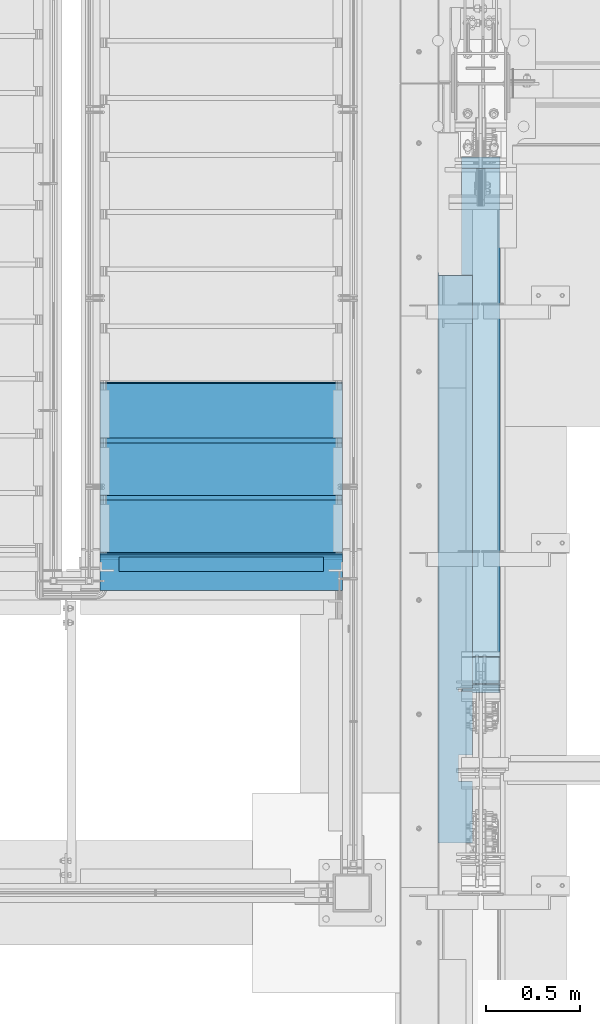
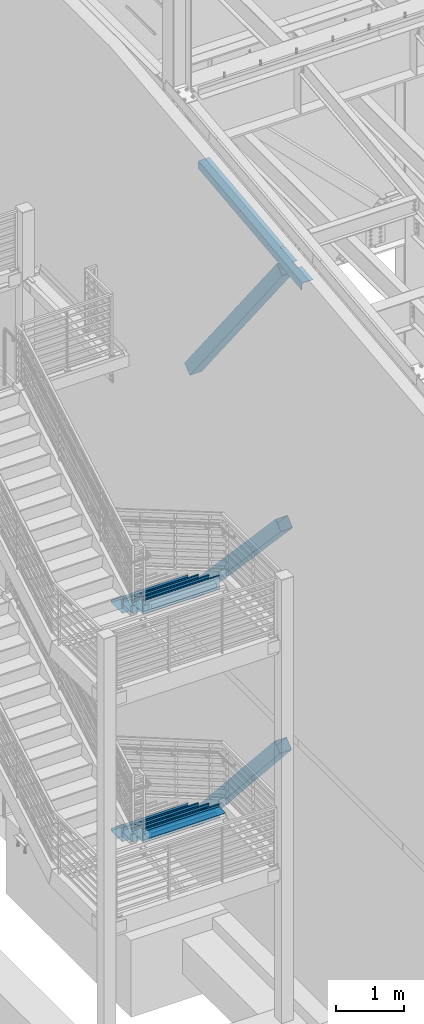
# One storey, part 760 of 1179: 10 beams, 3 members, 8 elements without a shape of their own.
"""IFC2X3 building model written with IfcOpenShell, lengths in millimetres."""

from ifc_helpers import new_model, si_unit, frame, origin_with_axes, place, context, subcontext, project, spatial, faceted_brep, material, type_object, element, aggregate, save


model = new_model("IFC2X3")

# Units and contexts
model_context = context("Model", 3, precision=1e-05, world=origin_with_axes())
body_context = subcontext(model_context, "Body", "Model", "MODEL_VIEW")
ifc_project = project(units=[si_unit("LENGTHUNIT", "METRE", prefix="MILLI"), si_unit("AREAUNIT", "SQUARE_METRE"), si_unit("VOLUMEUNIT", "CUBIC_METRE"), si_unit("MASSUNIT", "GRAM", prefix="KILO"), si_unit("TIMEUNIT", "SECOND"), si_unit("PLANEANGLEUNIT", "RADIAN"), si_unit("SOLIDANGLEUNIT", "STERADIAN"), si_unit("THERMODYNAMICTEMPERATUREUNIT", "DEGREE_CELSIUS"), si_unit("LUMINOUSINTENSITYUNIT", "LUMEN")], contexts=[model_context])

# Site, building, storey
site_placement = place(None, origin_with_axes())
site = spatial("IfcSite", under=ifc_project, at=site_placement, CompositionType="ELEMENT")
building_placement = place(site_placement, origin_with_axes())
building = spatial("IfcBuilding", under=site, at=building_placement, Name="Undefined", CompositionType="ELEMENT")
storey_placement = place(building_placement, origin_with_axes())
storey = spatial("IfcBuildingStorey", under=building, at=storey_placement, Name="Undefined", CompositionType="ELEMENT", Elevation=0.0)

# Assembly, beam
assembly_1_placement = place(storey_placement, origin_with_axes())
assembly_1 = element("IfcElementAssembly", 1, at=assembly_1_placement, inside=storey, Name="STRINGER", AssemblyPlace="NOTDEFINED", PredefinedType="RIGID_FRAME")
ifc_material_1 = material(Name="STEEL/A36")
beam_type_1 = type_object("IfcBeamType", PredefinedType="NOTDEFINED")
beam_1_placement = place(assembly_1_placement, frame((-952.50000002896, 31882.5089689556, 2101.24752361097), z_axis=(1.0, 0.0, 0.0), x_axis=(0.0, -0.142447497050996, -0.989802359354587)))
beam_1 = element("IfcBeam", 2, at=beam_1_placement, type_object=beam_type_1, material=ifc_material_1, Name="TREAD", context=body_context, shape_type="Brep", body=[
    faceted_brep([(-5.47515810467303e-10, -1.58750000000146, -647.7), (-5.47515810467303e-10, -1.58750000000146, 647.7), (5.49334799870849e-10, 1.58749999999418, 647.7), (5.49334799870849e-10, 1.58749999999418, -647.7), (37.6019506244984, 1.58749998704297, 647.7), (37.6019506244984, 1.58749998704297, -647.7), (34.8511855571105, -1.58750001201406, -647.7), (34.8511855571105, -1.58750001201406, 647.7), (64.9837450895284, -188.676249713546, 647.7), (64.9837450895284, -188.676249713546, -647.7), (61.8411225985801, -189.128520516686, 647.7), (61.8411225985801, -189.128520516686, -647.7)], [[[0, 1, 2, 3]], [[3, 2, 4, 5]], [[1, 0, 6, 7]], [[5, 4, 8, 9]], [[4, 2, 1, 7, 10, 8]], [[7, 6, 11, 10]], [[6, 0, 3, 5, 9, 11]], [[10, 11, 9, 8]]]),
])

assembly_2_placement = place(storey_placement, origin_with_axes())
assembly_2 = element("IfcElementAssembly", 3, at=assembly_2_placement, inside=storey, Name="BEAM", AssemblyPlace="NOTDEFINED", PredefinedType="RIGID_FRAME")
beam_type_2 = type_object("IfcBeamType", Name="L3X3X1/4", PredefinedType="NOTDEFINED")
beam_2_placement = place(assembly_2_placement, frame((-1498.59999999987, 31826.2000000043, 2025.70291883797), z_axis=(0.0, 0.0, -1.0), x_axis=(1.0, 0.0, 0.0)))
beam_2 = element("IfcBeam", 4, at=beam_2_placement, type_object=beam_type_2, material=ifc_material_1, Name="ANGLE", ObjectType="L3X3X1/4", context=body_context, shape_type="Brep", body=[
    faceted_brep([(0.0, 38.0999999999985, -38.0999999999999), (0.0, 38.0999999999985, 38.0999999999999), (1092.20000000289, 38.1000000000004, 38.0999999999985), (1092.20000000289, 38.1000000000004, -38.0999999999985), (0.0, 31.75, 38.1000000000004), (1092.20000000289, 31.75, 38.0999999999985), (0.0, 31.75, -31.75), (1092.20000000289, 31.75, -31.75), (0.0, -38.0999999999985, -31.75), (1092.20000000289, -38.1000000000004, -31.75), (0.0, -38.0999999999985, -38.0999999999999), (1092.20000000289, -38.1000000000004, -38.0999999999985)], [[[0, 1, 2, 3]], [[1, 4, 5, 2]], [[4, 6, 7, 5]], [[6, 8, 9, 7]], [[8, 10, 11, 9]], [[10, 0, 3, 11]], [[5, 7, 9, 11, 3, 2]], [[10, 8, 6, 4, 1, 0]]]),
])
aggregate(assembly_2, [beam_2])

assembly_3_placement = place(storey_placement, origin_with_axes())
assembly_3 = element("IfcElementAssembly", 5, at=assembly_3_placement, inside=storey, Name="BEAM", AssemblyPlace="NOTDEFINED", PredefinedType="RIGID_FRAME")
beam_3_placement = place(assembly_3_placement, frame((-1498.6, 31826.2, 6099.17499999882), z_axis=(0.0, 0.0, -1.0), x_axis=(1.0, 0.0, 0.0)))
beam_3 = element("IfcBeam", 6, at=beam_3_placement, type_object=beam_type_2, material=ifc_material_1, Name="ANGLE", ObjectType="L3X3X1/4", context=body_context, shape_type="Brep", body=[
    faceted_brep([(0.0, 38.0999999999985, -38.0999999999999), (0.0, 38.0999999999985, 38.0999999999999), (1092.20000000289, 38.1000000000004, 38.0999999999985), (1092.20000000289, 38.1000000000004, -38.0999999999985), (0.0, 31.75, 38.1000000000004), (1092.20000000289, 31.75, 38.0999999999985), (0.0, 31.75, -31.75), (1092.20000000289, 31.75, -31.75), (0.0, -38.0999999999985, -31.75), (1092.20000000289, -38.1000000000004, -31.75), (0.0, -38.0999999999985, -38.0999999999999), (1092.20000000289, -38.1000000000004, -38.0999999999985)], [[[0, 1, 2, 3]], [[1, 4, 5, 2]], [[4, 6, 7, 5]], [[6, 8, 9, 7]], [[8, 10, 11, 9]], [[10, 0, 3, 11]], [[5, 7, 9, 11, 3, 2]], [[10, 8, 6, 4, 1, 0]]]),
])
aggregate(assembly_3, [beam_3])

# Beam
beam_type_3 = type_object("IfcBeamType", PredefinedType="NOTDEFINED")
beam_4_placement = place(assembly_1_placement, frame((-952.499999979796, 31864.3000000037, 2116.19041883964), z_axis=(-1.0, 0.0, 0.0), x_axis=(0.0, 1.0, 0.0)))
beam_4 = element("IfcBeam", 7, at=beam_4_placement, type_object=beam_type_3, material=ifc_material_1, Name="TREAD", context=body_context, shape_type="Brep", body=[
    faceted_brep([(-5.47515810467303e-10, -1.58750000000146, -647.7), (-5.47515810467303e-10, -1.58750000000146, 647.7), (5.49334799870849e-10, 1.58749999999418, 647.7), (5.49334799870849e-10, 1.58749999999418, -647.7), (21.7353257776667, 1.58750000000009, 647.7), (21.7353257776667, 1.58750000000009, -647.7), (25.4000000001688, -1.58750000000009, -647.7), (25.4000000001688, -1.58750000000009, 647.7), (-10.9760191413625, 228.869394137143, 647.7), (-10.9760191413625, 228.869394137143, -647.7), (-7.31134491886041, 225.694394137142, -647.7), (-7.31134491886041, 225.694394137142, 647.7), (319.224134592409, 228.869394137143, 647.7), (319.224134592409, 228.869394137143, -647.7), (316.473378484785, 225.694394137142, -647.7), (316.473378484785, 225.694394137142, 647.7), (325.043579912828, 188.435270791671, 647.7), (325.043579912828, 188.435270791671, -647.7), (321.900961419207, 187.982972213801, 647.7), (321.900961419207, 187.982972213801, -647.7)], [[[0, 1, 2, 3]], [[3, 2, 4, 5]], [[1, 0, 6, 7]], [[5, 4, 8, 9]], [[7, 6, 10, 11]], [[9, 8, 12, 13]], [[11, 10, 14, 15]], [[13, 12, 16, 17]], [[12, 8, 4, 2, 1, 7, 11, 15, 18, 16]], [[15, 14, 19, 18]], [[14, 10, 6, 0, 3, 5, 9, 13, 17, 19]], [[18, 19, 17, 16]]]),
])

beam_5_placement = place(assembly_1_placement, frame((-952.499999979756, 32169.1001537378, 1939.70852470235), z_axis=(-1.0, 0.0, 0.0), x_axis=(0.0, 1.0, 0.0)))
beam_5 = element("IfcBeam", 8, at=beam_5_placement, type_object=beam_type_3, material=ifc_material_1, Name="TREAD", context=body_context, shape_type="Brep", body=[
    faceted_brep([(-5.47515810467303e-10, -1.58750000000146, -647.7), (-5.47515810467303e-10, -1.58750000000146, 647.7), (5.49334799870849e-10, 1.58749999999418, 647.7), (5.49334799870849e-10, 1.58749999999418, -647.7), (21.7353257776667, 1.58750000000009, 647.7), (21.7353257776667, 1.58750000000009, -647.7), (25.4000000001688, -1.58750000000009, -647.7), (25.4000000001688, -1.58750000000009, 647.7), (-10.9760191413625, 228.869394137143, 647.7), (-10.9760191413625, 228.869394137143, -647.7), (-7.31134491886041, 225.694394137142, -647.7), (-7.31134491886041, 225.694394137142, 647.7), (319.224134592409, 228.869394137143, 647.7), (319.224134592409, 228.869394137143, -647.7), (316.473378484785, 225.694394137142, -647.7), (316.473378484785, 225.694394137142, 647.7), (325.043579912828, 188.435270791671, 647.7), (325.043579912828, 188.435270791671, -647.7), (321.900961419207, 187.982972213801, 647.7), (321.900961419207, 187.982972213801, -647.7)], [[[0, 1, 2, 3]], [[3, 2, 4, 5]], [[1, 0, 6, 7]], [[5, 4, 8, 9]], [[7, 6, 10, 11]], [[9, 8, 12, 13]], [[11, 10, 14, 15]], [[13, 12, 16, 17]], [[12, 8, 4, 2, 1, 7, 11, 15, 18, 16]], [[15, 14, 19, 18]], [[14, 10, 6, 0, 3, 5, 9, 13, 17, 19]], [[18, 19, 17, 16]]]),
])

beam_6_placement = place(assembly_1_placement, frame((-952.499999979716, 32473.9003074718, 1763.22663056521), z_axis=(-1.0, 0.0, 0.0), x_axis=(0.0, 1.0, 0.0)))
beam_6 = element("IfcBeam", 9, at=beam_6_placement, type_object=beam_type_3, material=ifc_material_1, Name="TREAD", context=body_context, shape_type="Brep", body=[
    faceted_brep([(-5.47515810467303e-10, -1.58750000000146, -647.7), (-5.47515810467303e-10, -1.58750000000146, 647.7), (5.49334799870849e-10, 1.58749999999418, 647.7), (5.49334799870849e-10, 1.58749999999418, -647.7), (21.7353257776667, 1.58750000000009, 647.7), (21.7353257776667, 1.58750000000009, -647.7), (25.4000000001688, -1.58750000000009, -647.7), (25.4000000001688, -1.58750000000009, 647.7), (-10.9760191413625, 228.869394137143, 647.7), (-10.9760191413625, 228.869394137143, -647.7), (-7.31134491886041, 225.694394137142, -647.7), (-7.31134491886041, 225.694394137142, 647.7), (319.224134592409, 228.869394137143, 647.7), (319.224134592409, 228.869394137143, -647.7), (316.473378484785, 225.694394137142, -647.7), (316.473378484785, 225.694394137142, 647.7), (325.043579912828, 188.435270791671, 647.7), (325.043579912828, 188.435270791671, -647.7), (321.900961419207, 187.982972213801, 647.7), (321.900961419207, 187.982972213801, -647.7)], [[[0, 1, 2, 3]], [[3, 2, 4, 5]], [[1, 0, 6, 7]], [[5, 4, 8, 9]], [[7, 6, 10, 11]], [[9, 8, 12, 13]], [[11, 10, 14, 15]], [[13, 12, 16, 17]], [[12, 8, 4, 2, 1, 7, 11, 15, 18, 16]], [[15, 14, 19, 18]], [[14, 10, 6, 0, 3, 5, 9, 13, 17, 19]], [[18, 19, 17, 16]]]),
])

aggregate(assembly_1, [beam_1, beam_4, beam_5, beam_6])

# Assembly, member
assembly_4_placement = place(storey_placement, origin_with_axes())
assembly_4 = element("IfcElementAssembly", 10, at=assembly_4_placement, inside=storey, Name="None", AssemblyPlace="NOTDEFINED", PredefinedType="RIGID_FRAME")
ifc_material_2 = material(Name="STEEL/A992")
member_type = type_object("IfcMemberType", Name="HSS8X8X3/16", PredefinedType="NOTDEFINED")
member_1_placement = place(assembly_4_placement, frame((431.800000000002, 33919.5154724882, 8400.67856744961), z_axis=(-1.0, 0.0, 0.0), x_axis=(0.0, -0.620567780308726, 0.784152810390105)))
member_1 = element("IfcMember", 11, at=member_1_placement, type_object=member_type, material=ifc_material_2, Name="None", ObjectType="HSS8X8X3/16", context=body_context, shape_type="Brep", body=[
    faceted_brep([(-3.63797880709171e-12, 96.8374999999978, -96.8375000000015), (-3.63797880709171e-12, -96.8374999999978, -96.8375000000015), (4352.29000005135, -96.8374999959742, -96.8375), (4352.2900000514, 96.8375000037995, -96.8375), (-3.63797880709171e-12, -96.8374999999978, 96.8375000000015), (4352.29000005135, -96.8374999959742, 96.8375), (-3.63797880709171e-12, 96.8374999999978, 96.8375000000015), (4352.2900000514, 96.8375000037995, 96.8375), (-3.63797880709171e-12, 101.599999999999, -101.599999999999), (-3.63797880709171e-12, 101.599999999999, 101.599999999999), (4352.2900000514, 101.600000003793, 101.6), (4352.2900000514, 101.600000003793, -101.6), (0.0, -101.599999999999, 101.599999999999), (4352.29000005135, -101.599999995971, 101.6), (0.0, -101.599999999999, -101.599999999999), (4352.29000005135, -101.599999995971, -101.6)], [[[0, 1, 2, 3]], [[1, 4, 5, 2]], [[4, 6, 7, 5]], [[6, 0, 3, 7]], [[8, 9, 10, 11]], [[9, 12, 13, 10]], [[12, 14, 15, 13]], [[14, 8, 11, 15]], [[13, 15, 11, 10], [5, 7, 3, 2]], [[14, 12, 9, 8], [6, 4, 1, 0]]]),
])
aggregate(assembly_4, [member_1])

assembly_5_placement = place(storey_placement, origin_with_axes())
assembly_5 = element("IfcElementAssembly", 12, at=assembly_5_placement, inside=storey, Name="None", AssemblyPlace="NOTDEFINED", PredefinedType="RIGID_FRAME")
member_2_placement = place(assembly_5_placement, frame((431.800000000002, 33864.836589409, 4453.94491507543), z_axis=(-1.0, 0.0, 0.0), x_axis=(0.0, -0.684256097894612, 0.729241792887681)))
member_2 = element("IfcMember", 13, at=member_2_placement, type_object=member_type, material=ifc_material_2, Name="None", ObjectType="HSS8X8X3/16", context=body_context, shape_type="Brep", body=[
    faceted_brep([(-3.63797880709171e-12, 96.8374999999978, -96.8375000000015), (-3.63797880709171e-12, -96.8374999999978, -96.8375000000015), (3806.84458407234, -96.837499991303, -96.8375), (3806.84458407192, 96.8375000092055, -96.8375), (-3.63797880709171e-12, -96.8374999999978, 96.8375000000015), (3806.84458407234, -96.837499991303, 96.8375), (-3.63797880709171e-12, 96.8374999999978, 96.8375000000015), (3806.84458407192, 96.8375000092055, 96.8375), (-3.63797880709171e-12, 101.599999999999, -101.599999999999), (-3.63797880709171e-12, 101.599999999999, 101.599999999999), (3806.84458407191, 101.600000009224, 101.6), (3806.84458407191, 101.600000009224, -101.6), (0.0, -101.599999999999, 101.599999999999), (3806.84458407235, -101.599999991318, 101.6), (0.0, -101.599999999999, -101.599999999999), (3806.84458407235, -101.599999991318, -101.6)], [[[0, 1, 2, 3]], [[1, 4, 5, 2]], [[4, 6, 7, 5]], [[6, 0, 3, 7]], [[8, 9, 10, 11]], [[9, 12, 13, 10]], [[12, 14, 15, 13]], [[14, 8, 11, 15]], [[13, 15, 11, 10], [5, 7, 3, 2]], [[14, 12, 9, 8], [6, 4, 1, 0]]]),
])
aggregate(assembly_5, [member_2])

assembly_6_placement = place(storey_placement, origin_with_axes())
assembly_6 = element("IfcElementAssembly", 14, at=assembly_6_placement, inside=storey, Name="None", AssemblyPlace="NOTDEFINED", PredefinedType="RIGID_FRAME")
member_3_placement = place(assembly_6_placement, frame((431.800000000002, 33849.4627724086, 390.956033000802), z_axis=(-1.0, 0.0, 0.0), x_axis=(0.0, -0.666221892712435, 0.745753571678112)))
member_3 = element("IfcMember", 15, at=member_3_placement, type_object=member_type, material=ifc_material_2, Name="None", ObjectType="HSS8X8X3/16", context=body_context, shape_type="Brep", body=[
    faceted_brep([(-3.63797880709171e-12, 96.8374999999978, -96.8375000000015), (-3.63797880709171e-12, -96.8374999999978, -96.8375000000015), (3846.83000006713, -96.8375000095293, -96.8375), (3846.83000006755, 96.837499989997, -96.8375), (-3.63797880709171e-12, -96.8374999999978, 96.8375000000015), (3846.83000006713, -96.8375000095293, 96.8375), (-3.63797880709171e-12, 96.8374999999978, 96.8375000000015), (3846.83000006755, 96.837499989997, 96.8375), (-3.63797880709171e-12, 101.599999999999, -101.599999999999), (-3.63797880709171e-12, 101.599999999999, 101.599999999999), (3846.83000006756, 101.59999998999, 101.6), (3846.83000006756, 101.59999998999, -101.6), (0.0, -101.599999999999, 101.599999999999), (3846.83000006712, -101.600000009519, 101.6), (0.0, -101.599999999999, -101.599999999999), (3846.83000006712, -101.600000009519, -101.6)], [[[0, 1, 2, 3]], [[1, 4, 5, 2]], [[4, 6, 7, 5]], [[6, 0, 3, 7]], [[8, 9, 10, 11]], [[9, 12, 13, 10]], [[12, 14, 15, 13]], [[14, 8, 11, 15]], [[13, 15, 11, 10], [5, 7, 3, 2]], [[14, 12, 9, 8], [6, 4, 1, 0]]]),
])
aggregate(assembly_6, [member_3])

# Assembly, beams
assembly_7_placement = place(storey_placement, origin_with_axes())
assembly_7 = element("IfcElementAssembly", 16, at=assembly_7_placement, inside=storey, Name="STRINGER", AssemblyPlace="NOTDEFINED", PredefinedType="RIGID_FRAME")
beam_type_4 = type_object("IfcBeamType", PredefinedType="NOTDEFINED")
beam_7_placement = place(assembly_7_placement, frame((-952.499999972337, 31864.2999999957, 6189.66249999715), z_axis=(-1.0, 0.0, 0.0), x_axis=(0.0, 1.0, 0.0)))
beam_7 = element("IfcBeam", 17, at=beam_7_placement, type_object=beam_type_4, material=ifc_material_1, Name="TREAD", context=body_context, shape_type="Brep", body=[
    faceted_brep([(-5.47515810467303e-10, -1.58750000000146, -647.7), (-5.47515810467303e-10, -1.58750000000146, 647.7), (5.49334799870849e-10, 1.58749999999418, 647.7), (5.49334799870849e-10, 1.58749999999418, -647.7), (21.7391942417962, 1.58749999999964, 647.7), (21.7391942417962, 1.58749999999964, -647.7), (25.4000000001688, -1.58750000000009, -647.7), (25.4000000001688, -1.58750000000009, 647.7), (-10.9179486153444, 230.1875, 647.7), (-10.9179486153444, 230.1875, -647.7), (-7.25714285782306, 227.012500000001, -647.7), (-7.25714285782306, 227.012500000001, 647.7), (319.2820511338, 230.1875, 647.7), (319.2820511338, 230.1875, -647.7), (316.528388233419, 227.012500000001, -647.7), (316.528388233419, 227.012500000001, 647.7), (325.059631548502, 189.744437097058, 647.7), (325.059631548502, 189.744437097058, -647.7), (321.916541906132, 189.295424291005, 647.7), (321.916541906132, 189.295424291005, -647.7)], [[[0, 1, 2, 3]], [[3, 2, 4, 5]], [[1, 0, 6, 7]], [[5, 4, 8, 9]], [[7, 6, 10, 11]], [[9, 8, 12, 13]], [[11, 10, 14, 15]], [[13, 12, 16, 17]], [[12, 8, 4, 2, 1, 7, 11, 15, 18, 16]], [[15, 14, 19, 18]], [[14, 10, 6, 0, 3, 5, 9, 13, 17, 19]], [[18, 19, 17, 16]]]),
])
beam_8_placement = place(assembly_7_placement, frame((-952.499999968228, 32169.0999999612, 6011.8624998888), z_axis=(-1.0, 0.0, 0.0), x_axis=(0.0, 1.0, 0.0)))
beam_8 = element("IfcBeam", 18, at=beam_8_placement, type_object=beam_type_4, material=ifc_material_1, Name="TREAD", context=body_context, shape_type="Brep", body=[
    faceted_brep([(-5.47515810467303e-10, -1.58750000000146, -647.7), (-5.47515810467303e-10, -1.58750000000146, 647.7), (5.49334799870849e-10, 1.58749999999418, 647.7), (5.49334799870849e-10, 1.58749999999418, -647.7), (21.7391942417962, 1.58749999999964, 647.7), (21.7391942417962, 1.58749999999964, -647.7), (25.4000000001688, -1.58750000000009, -647.7), (25.4000000001688, -1.58750000000009, 647.7), (-10.9179486153444, 230.1875, 647.7), (-10.9179486153444, 230.1875, -647.7), (-7.25714285782306, 227.012500000001, -647.7), (-7.25714285782306, 227.012500000001, 647.7), (319.2820511338, 230.1875, 647.7), (319.2820511338, 230.1875, -647.7), (316.528388233419, 227.012500000001, -647.7), (316.528388233419, 227.012500000001, 647.7), (325.059631548502, 189.744437097058, 647.7), (325.059631548502, 189.744437097058, -647.7), (321.916541906132, 189.295424291005, 647.7), (321.916541906132, 189.295424291005, -647.7)], [[[0, 1, 2, 3]], [[3, 2, 4, 5]], [[1, 0, 6, 7]], [[5, 4, 8, 9]], [[7, 6, 10, 11]], [[9, 8, 12, 13]], [[11, 10, 14, 15]], [[13, 12, 16, 17]], [[12, 8, 4, 2, 1, 7, 11, 15, 18, 16]], [[15, 14, 19, 18]], [[14, 10, 6, 0, 3, 5, 9, 13, 17, 19]], [[18, 19, 17, 16]]]),
])
beam_9_placement = place(assembly_7_placement, frame((-952.499999972905, 32473.8999998973, 5834.06249977969), z_axis=(-1.0, 0.0, 0.0), x_axis=(0.0, 1.0, 0.0)))
beam_9 = element("IfcBeam", 19, at=beam_9_placement, type_object=beam_type_4, material=ifc_material_1, Name="TREAD", context=body_context, shape_type="Brep", body=[
    faceted_brep([(-5.47515810467303e-10, -1.58750000000146, -647.7), (-5.47515810467303e-10, -1.58750000000146, 647.7), (5.49334799870849e-10, 1.58749999999418, 647.7), (5.49334799870849e-10, 1.58749999999418, -647.7), (21.7391942417962, 1.58749999999964, 647.7), (21.7391942417962, 1.58749999999964, -647.7), (25.4000000001688, -1.58750000000009, -647.7), (25.4000000001688, -1.58750000000009, 647.7), (-10.9179486153444, 230.1875, 647.7), (-10.9179486153444, 230.1875, -647.7), (-7.25714285782306, 227.012500000001, -647.7), (-7.25714285782306, 227.012500000001, 647.7), (319.2820511338, 230.1875, 647.7), (319.2820511338, 230.1875, -647.7), (316.528388233419, 227.012500000001, -647.7), (316.528388233419, 227.012500000001, 647.7), (325.059631548502, 189.744437097058, 647.7), (325.059631548502, 189.744437097058, -647.7), (321.916541906132, 189.295424291005, 647.7), (321.916541906132, 189.295424291005, -647.7)], [[[0, 1, 2, 3]], [[3, 2, 4, 5]], [[1, 0, 6, 7]], [[5, 4, 8, 9]], [[7, 6, 10, 11]], [[9, 8, 12, 13]], [[11, 10, 14, 15]], [[13, 12, 16, 17]], [[12, 8, 4, 2, 1, 7, 11, 15, 18, 16]], [[15, 14, 19, 18]], [[14, 10, 6, 0, 3, 5, 9, 13, 17, 19]], [[18, 19, 17, 16]]]),
])
aggregate(assembly_7, [beam_7, beam_8, beam_9])

# Assembly, beam
assembly_8_placement = place(storey_placement, origin_with_axes())
assembly_8 = element("IfcElementAssembly", 20, at=assembly_8_placement, inside=storey, Name="BEAM", AssemblyPlace="NOTDEFINED", PredefinedType="RIGID_FRAME")
beam_type_5 = type_object("IfcBeamType", PredefinedType="NOTDEFINED")
beam_10_placement = place(assembly_8_placement, frame((388.937000141884, 31854.7938429563, 12320.818820592), z_axis=(0.0, -0.993676146336441, -0.112284087038017), x_axis=(-1.0, 0.0, 0.0)))
beam_10 = element("IfcBeam", 21, at=beam_10_placement, type_object=beam_type_5, material=ifc_material_1, Name="BENT_PLATE", context=body_context, shape_type="Brep", body=[
    faceted_brep([(76.19950014191, -3.17535420474633, 695.210957657477), (76.19950014191, 3.17525940907217, 695.210957657473), (-1.40403244586196e-11, 3.17499999971369, 695.210957657473), (-1.36424205265939e-11, -3.17500000028122, 695.210957657473), (76.19950014191, -3.17535420474996, 711.085957657288), (76.19950014191, 3.17525940906671, 711.085957657306), (-1.39834810397588e-11, -3.17500000028849, 711.085957657284), (-1.43813849717844e-11, 3.17499999970823, 711.085957657306), (76.1995001418825, -3.17500020422631, 1051.51788982531), (76.1995001418825, 3.17561340957764, 1051.51788982419), (0.0, 3.17500000042492, 1051.5178898197), (0.0, -3.17499999956999, 1051.51788982289), (76.1995001418825, -3.17500034578734, 1193.80812234997), (76.1995001418825, 3.17561326801115, 1193.80812234888), (-2.35900188272353e-11, -3.17500000048312, 1193.80812234997), (-2.3987922759261e-11, 3.1749999995136, 1193.80812234888), (6.00266503170133e-10, -3.17499999922438, 1524.00000000052), (6.00266503170133e-10, 3.17500000077416, 1524.00000000052), (185.737000203274, -3.17500000222026, 1523.9999999998), (185.737000201926, -3.17500000083055, -1523.99999999987), (185.737000202255, 136.524999793486, -1523.99999999991), (185.737000202948, 136.524999792873, 1523.99999999976), (179.387000203274, 3.1749999978274, 1523.9999999998), (179.387000202948, 136.524999792875, 1523.99999999976), (179.387000201926, 3.17499999921893, -1523.99999999987), (179.387000202255, 136.524999793486, -1523.99999999991), (0.0, -3.17499999999927, -1524.0), (0.0, 3.17499999999927, -1524.0)], [[[0, 1, 2, 3]], [[4, 5, 1, 0]], [[6, 7, 5, 4]], [[8, 9, 10, 11]], [[12, 13, 9, 8]], [[14, 15, 13, 12]], [[16, 17, 15, 14]], [[18, 19, 20, 21]], [[22, 17, 16, 18, 21, 23]], [[24, 22, 23, 25]], [[21, 20, 25, 23]], [[19, 26, 27, 24, 25, 20]], [[27, 26, 3, 2]], [[10, 9, 13, 15, 17, 22, 24, 27, 2, 1, 5, 7]], [[11, 10, 7, 6]], [[3, 26, 19, 18, 16, 14, 12, 8, 11, 6, 4, 0]]]),
])
aggregate(assembly_8, [beam_10])

save(model, "model.ifc")
